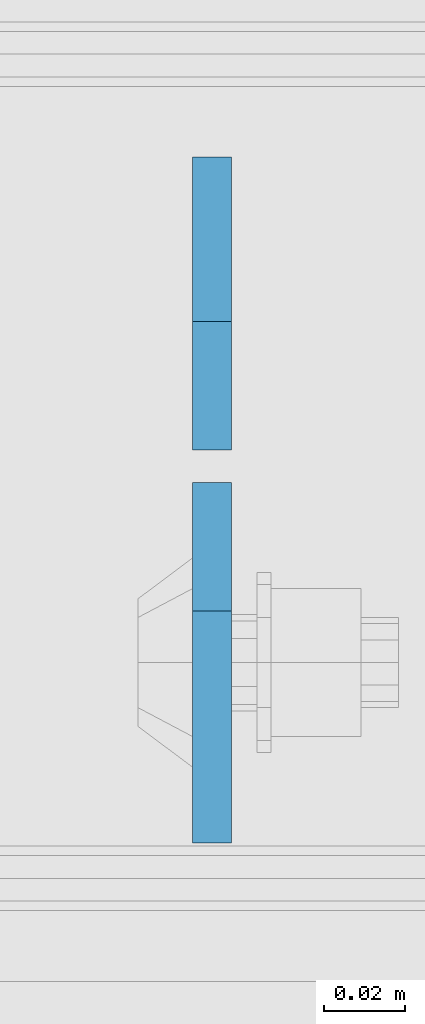
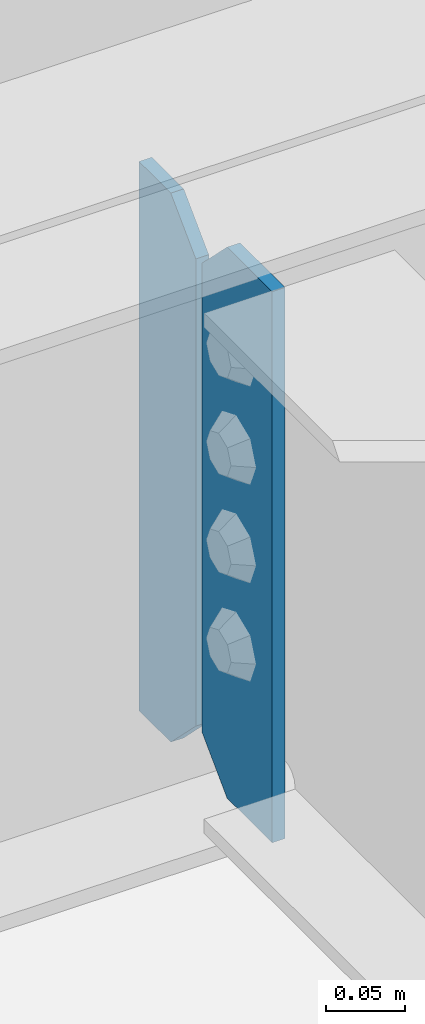
# One storey, part 3156 of 3843: 2 plates, 1 element without a shape of its own.
"""IFC2X3 building model written with IfcOpenShell, lengths in millimetres."""

from ifc_helpers import new_model, si_unit, frame, origin_with_axes, place, context, subcontext, project, spatial, faceted_brep, material, type_object, element, aggregate, save


model = new_model("IFC2X3")

# Units and contexts
model_context = context("Model", 3, precision=1e-05, world=origin_with_axes())
body_context = subcontext(model_context, "Body", "Model", "MODEL_VIEW")
ifc_project = project(units=[si_unit("LENGTHUNIT", "METRE", prefix="MILLI"), si_unit("AREAUNIT", "SQUARE_METRE"), si_unit("VOLUMEUNIT", "CUBIC_METRE"), si_unit("MASSUNIT", "GRAM", prefix="KILO"), si_unit("TIMEUNIT", "SECOND"), si_unit("PLANEANGLEUNIT", "RADIAN"), si_unit("SOLIDANGLEUNIT", "STERADIAN"), si_unit("THERMODYNAMICTEMPERATUREUNIT", "DEGREE_CELSIUS"), si_unit("LUMINOUSINTENSITYUNIT", "LUMEN")], contexts=[model_context])

# Site, building, storey
site_placement = place(None, origin_with_axes())
site = spatial("IfcSite", under=ifc_project, at=site_placement, CompositionType="ELEMENT")
building_placement = place(site_placement, origin_with_axes())
building = spatial("IfcBuilding", under=site, at=building_placement, Name="Undefined", CompositionType="ELEMENT")
storey_placement = place(building_placement, origin_with_axes())
storey = spatial("IfcBuildingStorey", under=building, at=storey_placement, Name="Undefined", CompositionType="ELEMENT", Elevation=0.0)

# Assembly, plates
assembly_placement = place(storey_placement, origin_with_axes())
assembly = element("IfcElementAssembly", 1, at=assembly_placement, inside=storey, Name="BEAM", AssemblyPlace="NOTDEFINED", PredefinedType="RIGID_FRAME")
ifc_material = material(Name="STEEL/A572-50")
plate_type_1 = type_object("IfcPlateType", PredefinedType="NOTDEFINED")
plate_1_placement = place(assembly_placement, frame((58158.0620000839, 25611.93125, 34372.55), z_axis=(0.0, 0.0, 1.0), x_axis=(0.0, -1.0, 0.0)))
plate_1 = element("IfcPlate", 2, at=plate_1_placement, type_object=plate_type_1, material=ifc_material, Name="PLATE", context=body_context, shape_type="Brep", body=[
    faceted_brep([(0.0, -4.76249999999709, 31.75), (0.0, -4.76250000000073, 395.287506103516), (0.0, 4.76250000000073, 395.287506103516), (0.0, 4.76249999999709, 31.75), (31.75, -4.76250000000073, 427.037506103516), (31.75, 4.76250000000073, 427.037506103516), (88.8999999999996, -4.76249999999709, 427.037499999999), (88.8999999999996, 4.76249999999709, 427.037499999999), (88.8999999999942, -4.76250000000073, 0.0), (88.8999999999942, 4.76250000000073, 0.0), (31.75, -4.76249999999709, 0.0), (31.75, 4.76249999999709, 0.0)], [[[0, 1, 2, 3]], [[1, 4, 5, 2]], [[4, 6, 7, 5]], [[6, 8, 9, 7]], [[8, 10, 11, 9]], [[10, 0, 3, 11]], [[5, 7, 9, 11, 3, 2]], [[10, 8, 6, 4, 1, 0]]]),
])
plate_type_2 = type_object("IfcPlateType", PredefinedType="NOTDEFINED")
plate_2_placement = place(assembly_placement, frame((58158.0624999998, 25619.86875, 34372.55), z_axis=(0.0, 0.0, 1.0), x_axis=(0.0, 1.0, 0.0)))
plate_2 = element("IfcPlate", 3, at=plate_2_placement, type_object=plate_type_2, material=ifc_material, Name="PLATE", context=body_context, shape_type="Brep", body=[
    faceted_brep([(0.0, -4.76249999999709, 31.75), (0.0, -4.76249999999709, 393.699999999997), (0.0, 4.76249999999709, 393.699999999997), (0.0, 4.76249999999709, 31.75), (31.75, -4.76249999999709, 425.449999999997), (31.75, 4.76249999999709, 425.449999999997), (72.2312469482422, -4.76249999999709, 425.450012207031), (72.2312469482422, 4.76249999999709, 425.450012207031), (72.2312469482422, -4.76249999999709, 0.0), (72.2312469482422, 4.76249999999709, 0.0), (31.75, -4.76249999999709, 0.0), (31.75, 4.76249999999709, 0.0)], [[[0, 1, 2, 3]], [[1, 4, 5, 2]], [[4, 6, 7, 5]], [[6, 8, 9, 7]], [[8, 10, 11, 9]], [[10, 0, 3, 11]], [[5, 7, 9, 11, 3, 2]], [[10, 8, 6, 4, 1, 0]]]),
])
aggregate(assembly, [plate_2, plate_1])

save(model, "model.ifc")
